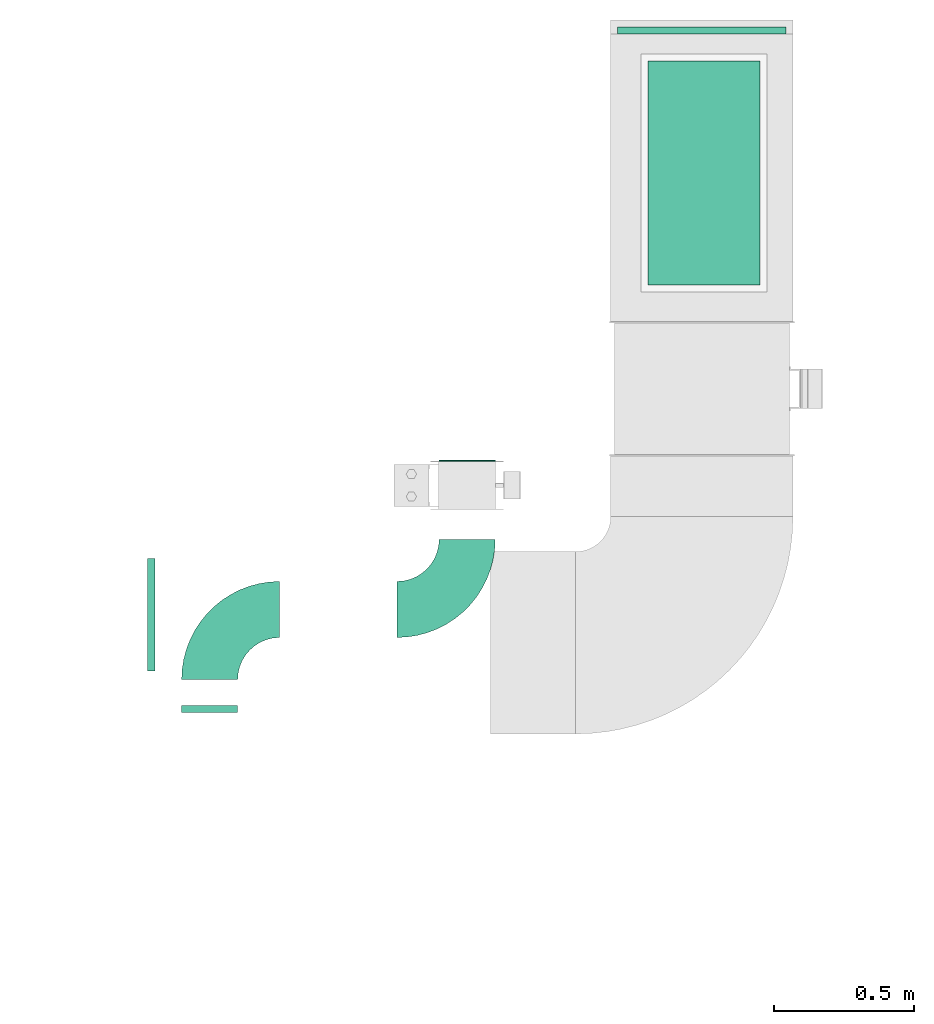
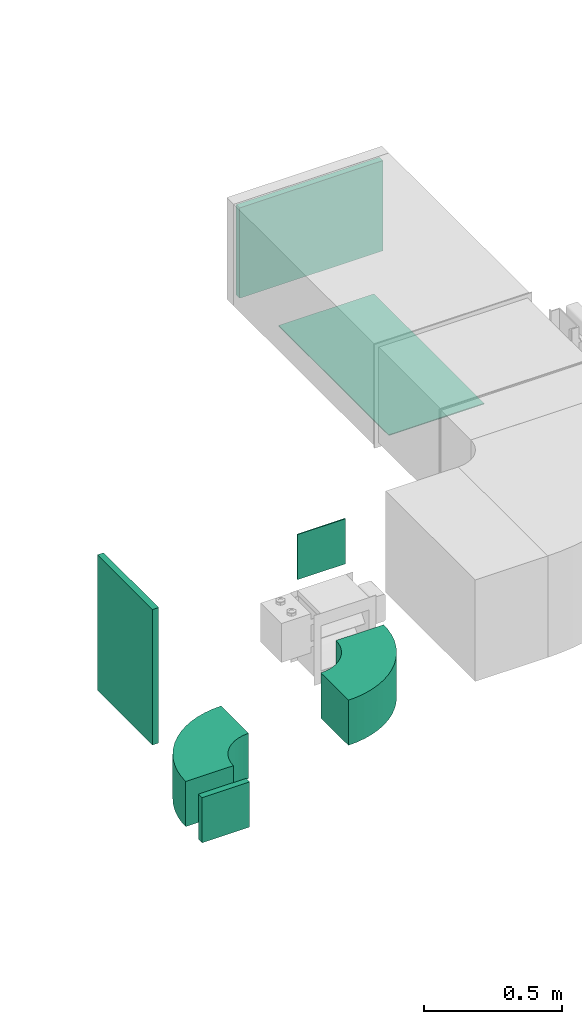
# One storey, part 3 of 8: 5 flow fittings, 2 flow terminals.
"""IFC2X3 building model written with IfcOpenShell, lengths in millimetres."""

from ifc_helpers import new_model, entity, si_unit, converted_unit, derived_unit, direction, frame, frame_2d, origin, origin_2d_with_axis, place, context, subcontext, project, spatial, polyline, circle_curve, parameter, trimmed, segment, composite_curve, rectangle, outline, extrude, source, transform, mapped, material, type_object, type_shapes, element, save


model = new_model("IFC2X3")

# Units and contexts
model_context = context("Model", 3, precision=0.01, world=origin(), true_north=direction((6.12303176911189e-17, 1.0)))
body_context = subcontext(model_context, "Body", "Model", "MODEL_VIEW")
ifc_project = project(units=[si_unit("LENGTHUNIT", "METRE", prefix="MILLI"), si_unit("AREAUNIT", "SQUARE_METRE"), si_unit("VOLUMEUNIT", "CUBIC_METRE"), converted_unit("PLANEANGLEUNIT", "DEGREE", entity("IfcRatioMeasure", 0.0174532925199433), si_unit("PLANEANGLEUNIT", "RADIAN"), dimensions=[0, 0, 0, 0, 0, 0, 0]), si_unit("MASSUNIT", "GRAM", prefix="KILO"), derived_unit("MASSDENSITYUNIT", [(si_unit("MASSUNIT", "GRAM", prefix="KILO"), 1), (si_unit("LENGTHUNIT", "METRE"), -3)]), derived_unit("MOMENTOFINERTIAUNIT", [(si_unit("LENGTHUNIT", "METRE"), 4)]), si_unit("TIMEUNIT", "SECOND"), si_unit("FREQUENCYUNIT", "HERTZ"), si_unit("THERMODYNAMICTEMPERATUREUNIT", "DEGREE_CELSIUS"), derived_unit("THERMALTRANSMITTANCEUNIT", [(si_unit("MASSUNIT", "GRAM", prefix="KILO"), 1), (si_unit("THERMODYNAMICTEMPERATUREUNIT", "KELVIN"), -1), (si_unit("TIMEUNIT", "SECOND"), -3)]), derived_unit("VOLUMETRICFLOWRATEUNIT", [(si_unit("LENGTHUNIT", "METRE"), 3), (si_unit("TIMEUNIT", "SECOND"), -1)]), derived_unit("MASSFLOWRATEUNIT", [(si_unit("MASSUNIT", "GRAM", prefix="KILO"), 1), (si_unit("TIMEUNIT", "SECOND"), -1)]), derived_unit("ROTATIONALFREQUENCYUNIT", [(si_unit("TIMEUNIT", "SECOND"), -1)]), si_unit("ELECTRICCURRENTUNIT", "AMPERE"), si_unit("ELECTRICVOLTAGEUNIT", "VOLT"), si_unit("POWERUNIT", "WATT"), si_unit("FORCEUNIT", "NEWTON", prefix="KILO"), si_unit("ILLUMINANCEUNIT", "LUX"), si_unit("LUMINOUSFLUXUNIT", "LUMEN"), si_unit("LUMINOUSINTENSITYUNIT", "CANDELA"), derived_unit("USERDEFINED", [(si_unit("MASSUNIT", "GRAM", prefix="KILO"), -1), (si_unit("LENGTHUNIT", "METRE"), -2), (si_unit("TIMEUNIT", "SECOND"), 3), (si_unit("LUMINOUSFLUXUNIT", "LUMEN"), 1)]), derived_unit("LINEARVELOCITYUNIT", [(si_unit("LENGTHUNIT", "METRE"), 1), (si_unit("TIMEUNIT", "SECOND"), -1)]), si_unit("PRESSUREUNIT", "PASCAL"), derived_unit("USERDEFINED", [(si_unit("LENGTHUNIT", "METRE"), -2), (si_unit("MASSUNIT", "GRAM", prefix="KILO"), 1), (si_unit("TIMEUNIT", "SECOND"), -2)]), derived_unit("LINEARFORCEUNIT", [(si_unit("MASSUNIT", "GRAM", prefix="KILO"), 1), (si_unit("LENGTHUNIT", "METRE"), 1), (si_unit("TIMEUNIT", "SECOND"), -2), (si_unit("LENGTHUNIT", "METRE"), -1)]), derived_unit("PLANARFORCEUNIT", [(si_unit("MASSUNIT", "GRAM", prefix="KILO"), 1), (si_unit("LENGTHUNIT", "METRE"), 1), (si_unit("TIMEUNIT", "SECOND"), -2), (si_unit("LENGTHUNIT", "METRE"), -2)])], contexts=[model_context])

# Site, building, storey
site_placement = place(None, frame((0.0, -0.00077364408347762, 0.0)))
site = spatial("IfcSite", under=ifc_project, at=site_placement, CompositionType="ELEMENT")
building_placement = place(site_placement, origin())
building = spatial("IfcBuilding", under=site, at=building_placement, CompositionType="ELEMENT")
storey_placement = place(building_placement, frame((0.0, 0.0, 4200.0)))
storey = spatial("IfcBuildingStorey", under=building, at=storey_placement, CompositionType="ELEMENT", Elevation=4200.0)

# Flow fittings
ifc_material_1 = material()
duct_fitting_type_1 = type_object("IfcDuctFittingType", PredefinedType="NOTDEFINED", material=ifc_material_1)
shared_shape_1 = source(origin(), body_context, "Body", "SweptSolid", [
    extrude(rectangle(XDim=26.0960000000009, YDim=600.0, at=frame_2d((-4.66293670342566e-13, -1.4210854715202e-13), x_axis=(1.0, 0.0))), frame((6.95199999999999, 0.0, -200.0)), (0.0, 0.0, 1.0), 400.0),
])
type_shapes(duct_fitting_type_1, [shared_shape_1])
flow_fitting_1_placement = place(storey_placement, frame((10029.7340134019, 14794.0835453812, 3285.13492759623), z_axis=(0.0, -1.0, 0.0), x_axis=(1.0, 0.0, 0.0)))
element("IfcFlowFitting", 1, at=flow_fitting_1_placement, inside=storey, type_object=duct_fitting_type_1, material=ifc_material_1, context=body_context, shape_type="MappedRepresentation", body=[
    mapped(shared_shape_1, transform((0.0, 0.0, 0.0), scale=1.0)),
])
duct_fitting_type_2 = type_object("IfcDuctFittingType", PredefinedType="NOTDEFINED", material=ifc_material_1)
shared_shape_2 = source(origin(), body_context, "Body", "SweptSolid", [
    extrude(rectangle(XDim=24.9999999999999, YDim=600.0, at=frame_2d((-2.46913600676635e-13, 0.0), x_axis=(1.0, 0.0))), frame((12.500000000006, 0.0, -200.0)), (0.0, 0.0, 1.0), 400.0),
])
type_shapes(duct_fitting_type_2, [shared_shape_2])
flow_fitting_2_placement = place(storey_placement, frame((12000.2194386704, 16865.3805781061, 3200.0), z_axis=(0.0, 0.0, 1.0), x_axis=(0.0, 1.0, 0.0)))
element("IfcFlowFitting", 2, at=flow_fitting_2_placement, inside=storey, type_object=duct_fitting_type_2, material=ifc_material_1, context=body_context, shape_type="MappedRepresentation", body=[
    mapped(shared_shape_2, transform((0.0, 0.0, 0.0), scale=1.0)),
])

# Flow terminal
ifc_material_2 = material()
air_terminal_type_1 = type_object("IfcAirTerminalType", PredefinedType="NOTDEFINED", material=ifc_material_2)
shared_shape_3 = source(origin(), body_context, "Body", "SweptSolid", [
    extrude(rectangle(XDim=4.0, YDim=799.999999999999, at=origin_2d_with_axis()), frame((0.0, -2.0, -200.0), z_axis=(0.0, 0.0, 1.0), x_axis=(0.0, 1.0, 0.0)), (0.0, 0.0, 1.0), 400.000000000005),
])
type_shapes(air_terminal_type_1, [shared_shape_3])
flow_terminal_1_placement = place(storey_placement, frame((12008.2194386705, 16369.9705979415, 2900.0), z_axis=(-1.0, 0.0, 0.0), x_axis=(0.0, -1.0, 0.0)))
element("IfcFlowTerminal", 3, at=flow_terminal_1_placement, inside=storey, type_object=air_terminal_type_1, material=ifc_material_2, context=body_context, shape_type="MappedRepresentation", body=[
    mapped(shared_shape_3, transform((0.0, 0.0, 0.0), scale=1.0)),
])

# Flow fittings
duct_fitting_type_3 = type_object("IfcDuctFittingType", PredefinedType="NOTDEFINED", material=ifc_material_1)
shared_shape_4 = source(origin(), body_context, "Body", "SweptSolid", [
    extrude(outline(composite_curve([segment(polyline([(-225.0, -125.0), (-25.0, -125.0)]), True, "CONTINUOUS"), segment(trimmed(circle_curve(frame_2d((125.0, -125.0), x_axis=(0.0, 1.0)), 150.0), [parameter(0.0)], [parameter(90.0000000000001)], True, "PARAMETER"), False, "CONTINUOUS"), segment(polyline([(125.0, 25.0), (125.0, 225.0)]), True, "CONTINUOUS"), segment(trimmed(circle_curve(frame_2d((125.0, -125.0), x_axis=(0.0, 1.0)), 350.0), [parameter(0.0)], [parameter(90.0000000000001)], True, "PARAMETER"), True, "CONTINUOUS")], self_intersect=False)), frame((-125.0, 125.0, -100.0), z_axis=(0.0, 0.0, 1.0), x_axis=(-1.0, 0.0, 0.0)), (0.0, 0.0, 1.0), 200.0),
])
type_shapes(duct_fitting_type_3, [shared_shape_4])
flow_fitting_3_placement = place(storey_placement, frame((11163.2485954877, 14813.0483402227, 2700.0)))
element("IfcFlowFitting", 4, at=flow_fitting_3_placement, inside=storey, type_object=duct_fitting_type_3, material=ifc_material_1, context=body_context, shape_type="MappedRepresentation", body=[
    mapped(shared_shape_4, transform((0.0, 0.0, 0.0), scale=1.0)),
])
flow_fitting_4_placement = place(storey_placement, frame((10244.7174683872, 14813.0483402227, 2700.0), z_axis=(0.0, 0.0, 1.0), x_axis=(-1.0, 0.0, 0.0)))
element("IfcFlowFitting", 5, at=flow_fitting_4_placement, inside=storey, type_object=duct_fitting_type_3, material=ifc_material_1, context=body_context, shape_type="MappedRepresentation", body=[
    mapped(shared_shape_4, transform((0.0, 0.0, 0.0), scale=1.0)),
])

# Flow terminal
air_terminal_type_2 = type_object("IfcAirTerminalType", PredefinedType="NOTDEFINED", material=ifc_material_2)
shared_shape_5 = source(origin(), body_context, "Body", "SweptSolid", [
    extrude(rectangle(XDim=4.0, YDim=199.999999999999, at=origin_2d_with_axis()), frame((0.0, -2.0, -100.0), z_axis=(0.0, 0.0, 1.0), x_axis=(0.0, 1.0, 0.0)), (0.0, 0.0, 1.0), 200.000000000005),
])
type_shapes(air_terminal_type_2, [shared_shape_5])
flow_terminal_2_placement = place(storey_placement, frame((11163.2485954877, 15341.8805781061, 3000.0), z_axis=(0.0, 0.0, 1.0), x_axis=(-1.0, 0.0, 0.0)))
element("IfcFlowTerminal", 6, at=flow_terminal_2_placement, inside=storey, type_object=air_terminal_type_2, material=ifc_material_2, context=body_context, shape_type="MappedRepresentation", body=[
    mapped(shared_shape_5, transform((0.0, 0.0, 0.0), scale=1.0)),
])

# Flow fitting
duct_fitting_type_4 = type_object("IfcDuctFittingType", PredefinedType="NOTDEFINED", material=ifc_material_1)
shared_shape_6 = source(origin(), body_context, "Body", "SweptSolid", [
    extrude(rectangle(XDim=26.0960000000003, YDim=200.0, at=frame_2d((-1.57207580286922e-13, -9.9475983006414e-14), x_axis=(1.0, 0.0))), frame((6.95199999999999, 0.0, -100.0)), (0.0, 0.0, 1.0), 200.0),
])
type_shapes(duct_fitting_type_4, [shared_shape_6])
flow_fitting_5_placement = place(storey_placement, frame((10244.7174683872, 14450.8402530397, 2700.0), z_axis=(1.0, 0.0, 0.0), x_axis=(0.0, 1.0, 0.0)))
element("IfcFlowFitting", 7, at=flow_fitting_5_placement, inside=storey, type_object=duct_fitting_type_4, material=ifc_material_1, context=body_context, shape_type="MappedRepresentation", body=[
    mapped(shared_shape_6, transform((0.0, 0.0, 0.0), scale=1.0)),
])

save(model, "model.ifc")
